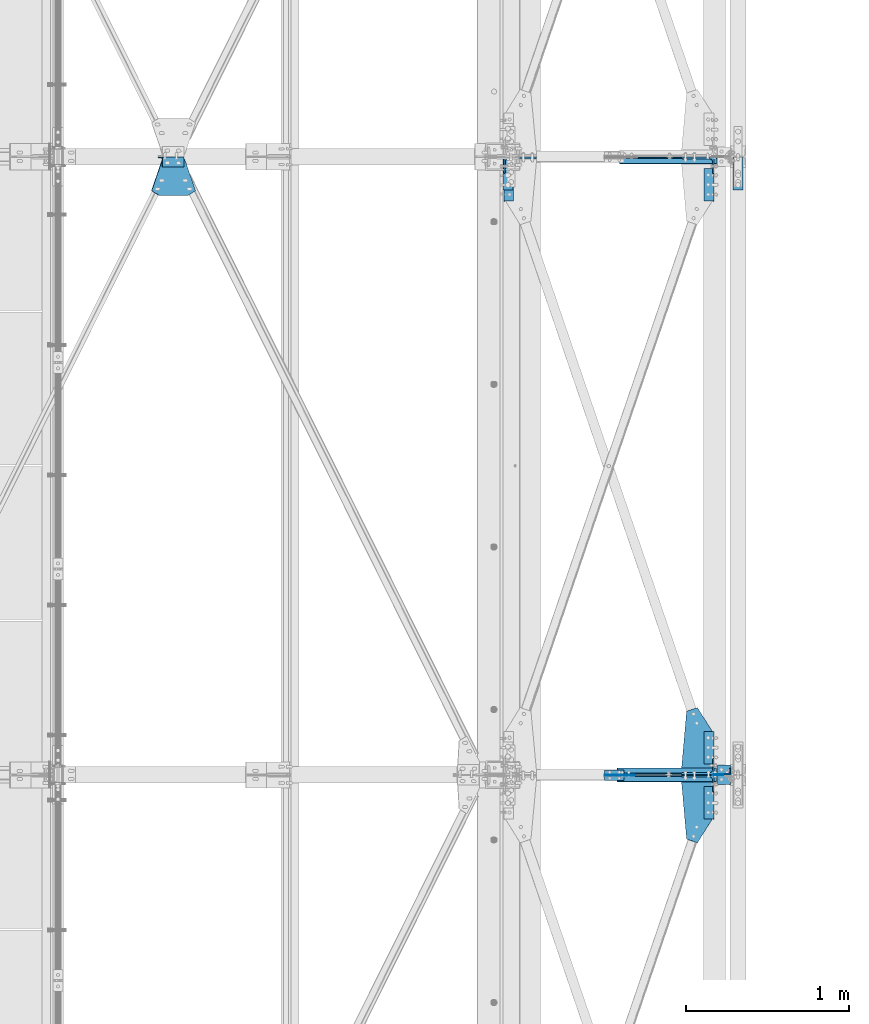
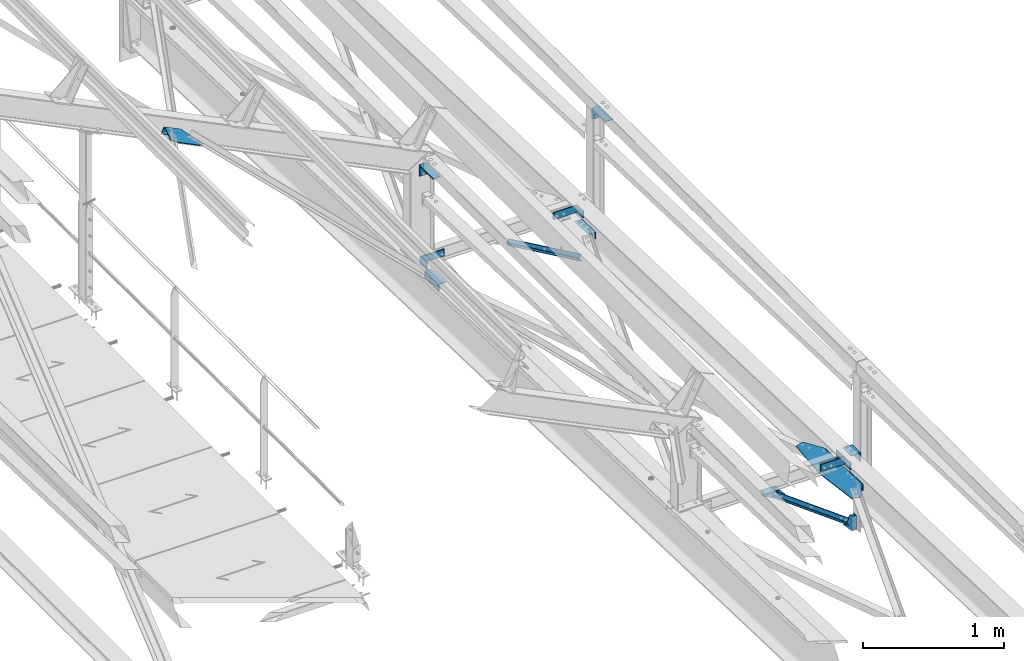
# One storey, part 109 of 496: 13 beams, 8 members, 20 elements without a shape of their own.
"""IFC2X3 building model written with IfcOpenShell, lengths in millimetres."""

from ifc_helpers import new_model, si_unit, frame, origin_with_axes, origin_2d_with_axis, place, context, subcontext, project, spatial, polyline, rectangle, l_section, outline, extrude, clip, halfspace, material, type_object, element, aggregate, save


model = new_model("IFC2X3")

# Units and contexts
model_context = context("Model", 3, precision=1e-05, world=origin_with_axes())
body_context = subcontext(model_context, "Body", "Model", "MODEL_VIEW")
ifc_project = project(units=[si_unit("LENGTHUNIT", "METRE", prefix="MILLI"), si_unit("AREAUNIT", "SQUARE_METRE"), si_unit("VOLUMEUNIT", "CUBIC_METRE"), si_unit("MASSUNIT", "GRAM", prefix="KILO"), si_unit("TIMEUNIT", "SECOND"), si_unit("PLANEANGLEUNIT", "RADIAN"), si_unit("SOLIDANGLEUNIT", "STERADIAN"), si_unit("THERMODYNAMICTEMPERATUREUNIT", "DEGREE_CELSIUS"), si_unit("LUMINOUSINTENSITYUNIT", "LUMEN")], contexts=[model_context])

# Site, building, storey
site_placement = place(None, origin_with_axes())
site = spatial("IfcSite", under=ifc_project, at=site_placement, CompositionType="ELEMENT")
building_placement = place(site_placement, origin_with_axes())
building = spatial("IfcBuilding", under=site, at=building_placement, Name="Undefined", CompositionType="ELEMENT")
storey_placement = place(building_placement, origin_with_axes())
storey = spatial("IfcBuildingStorey", under=building, at=storey_placement, Name="Undefined", CompositionType="ELEMENT", Elevation=0.0)

# Assembly, beam
assembly_1_placement = place(storey_placement, origin_with_axes())
assembly_1 = element("IfcElementAssembly", 1, at=assembly_1_placement, inside=storey, AssemblyPlace="NOTDEFINED", PredefinedType="NOTDEFINED")
ifc_material = material(Name="Undefined/S235-E24")
beam_type_1 = type_object("IfcBeamType", PredefinedType="NOTDEFINED")
beam_1_placement = place(assembly_1_placement, frame((39596.4999999987, 7327.11779121703, 7663.65903284788), z_axis=(0.0, -0.031410887010906, -0.999506556345274), x_axis=(0.0, 0.999506556345274, -0.0314108870109058)))
beam_1 = element("IfcBeam", 2, at=beam_1_placement, type_object=beam_type_1, material=ifc_material, context=body_context, shape_type="SweptSolid", body=[
    extrude(l_section(Depth=60.0, Width=60.0, Thickness=6.0, FilletRadius=8.0, EdgeRadius=4.0, at=origin_2d_with_axis()), frame((200.0, 0.0, 0.0), z_axis=(-1.0, 0.0, 0.0), x_axis=(0.0, -1.0, 0.0)), (0.0, 0.0, 1.0), 200.0),
])
aggregate(assembly_1, [beam_1])

assembly_2_placement = place(storey_placement, origin_with_axes())
assembly_2 = element("IfcElementAssembly", 3, at=assembly_2_placement, inside=storey, AssemblyPlace="NOTDEFINED", PredefinedType="NOTDEFINED")
beam_2_placement = place(assembly_2_placement, frame((39596.4999999987, 7666.95002289422, 7652.97941150256), z_axis=(0.0, -0.031410887010906, -0.999506556345274), x_axis=(0.0, 0.999506556345274, -0.0314108870109058)))
beam_2 = element("IfcBeam", 4, at=beam_2_placement, type_object=beam_type_1, material=ifc_material, context=body_context, shape_type="SweptSolid", body=[
    extrude(l_section(Depth=60.0, Width=60.0, Thickness=6.0, FilletRadius=8.0, EdgeRadius=4.0, at=origin_2d_with_axis()), frame((200.0, 0.0, 0.0), z_axis=(-1.0, 0.0, 0.0), x_axis=(0.0, -1.0, 0.0)), (0.0, 0.0, 1.0), 200.0),
])
aggregate(assembly_2, [beam_2])

assembly_3_placement = place(storey_placement, origin_with_axes())
assembly_3 = element("IfcElementAssembly", 5, at=assembly_3_placement, inside=storey, AssemblyPlace="NOTDEFINED", PredefinedType="NOTDEFINED")
beam_3_placement = place(assembly_3_placement, frame((39596.4999999987, 11127.1177919487, 7544.23922211323), z_axis=(0.0, -0.031410887010906, -0.999506556345274), x_axis=(0.0, 0.999506556345274, -0.0314108870109058)))
beam_3 = element("IfcBeam", 6, at=beam_3_placement, type_object=beam_type_1, material=ifc_material, context=body_context, shape_type="SweptSolid", body=[
    extrude(l_section(Depth=60.0, Width=60.0, Thickness=6.0, FilletRadius=8.0, EdgeRadius=4.0, at=origin_2d_with_axis()), frame((200.0, 0.0, 0.0), z_axis=(-1.0, 0.0, 0.0), x_axis=(0.0, -1.0, 0.0)), (0.0, 0.0, 1.0), 200.0),
])
aggregate(assembly_3, [beam_3])

assembly_4_placement = place(storey_placement, origin_with_axes())
assembly_4 = element("IfcElementAssembly", 7, at=assembly_4_placement, inside=storey, AssemblyPlace="NOTDEFINED", PredefinedType="NOTDEFINED")
beam_4_placement = place(assembly_4_placement, frame((38365.0000000024, 11327.0191028577, 7537.95703356359), z_axis=(0.0, -0.031410887010906, -0.999506556345274), x_axis=(0.0, -0.999506556345276, 0.031410887010852)))
beam_4 = element("IfcBeam", 8, at=beam_4_placement, type_object=beam_type_1, material=ifc_material, context=body_context, shape_type="SweptSolid", body=[
    extrude(l_section(Depth=60.0, Width=60.0, Thickness=6.0, FilletRadius=8.0, EdgeRadius=4.0, at=origin_2d_with_axis()), frame((200.0, 0.0, 0.0), z_axis=(-1.0, 0.0, 0.0), x_axis=(0.0, -1.0, 0.0)), (0.0, 0.0, 1.0), 200.0),
])
aggregate(assembly_4, [beam_4])

assembly_5_placement = place(storey_placement, origin_with_axes())
assembly_5 = element("IfcElementAssembly", 9, at=assembly_5_placement, inside=storey, AssemblyPlace="NOTDEFINED", PredefinedType="NOTDEFINED")
beam_type_2 = type_object("IfcBeamType", PredefinedType="NOTDEFINED")
beam_5_placement = place(assembly_5_placement, frame((39689.0, 7660.12744744233, 7759.04601471418), z_axis=(-1.0, 0.0, 0.0), x_axis=(0.0, -0.999506556345276, 0.031410887010852)))
beam_5 = element("IfcBeam", 10, at=beam_5_placement, type_object=beam_type_2, material=ifc_material, context=body_context, shape_type="SweptSolid", body=[
    extrude(l_section(Depth=80.0, Width=80.0, Thickness=8.0, FilletRadius=10.0, EdgeRadius=5.0, at=origin_2d_with_axis()), frame((120.0, 0.0, 0.0), z_axis=(-1.0, 0.0, 0.0), x_axis=(0.0, -1.0, 0.0)), (0.0, 0.0, 1.0), 120.0),
])
aggregate(assembly_5, [beam_5])

assembly_6_placement = place(storey_placement, origin_with_axes())
assembly_6 = element("IfcElementAssembly", 11, at=assembly_6_placement, inside=storey, AssemblyPlace="NOTDEFINED", PredefinedType="NOTDEFINED")
beam_type_3 = type_object("IfcBeamType", PredefinedType="NOTDEFINED")
beam_6_placement = place(assembly_6_placement, frame((39709.0000003665, 7623.0, 7220.00000925125), z_axis=(-1.0, 0.0, 0.0), x_axis=(0.0, 0.0, -1.0)))
beam_6 = element("IfcBeam", 12, at=beam_6_placement, type_object=beam_type_3, material=ifc_material, context=body_context, shape_type="SweptSolid", body=[
    extrude(l_section(Depth=40.0, Width=40.0, Thickness=4.0, FilletRadius=6.0, EdgeRadius=3.0, at=origin_2d_with_axis()), frame((120.0, 0.0, 0.0), z_axis=(-1.0, 0.0, 0.0), x_axis=(0.0, -1.0, 0.0)), (0.0, 0.0, 1.0), 120.0),
])
aggregate(assembly_6, [beam_6])

# Assembly, member
assembly_7_placement = place(storey_placement, origin_with_axes())
assembly_7 = element("IfcElementAssembly", 13, at=assembly_7_placement, inside=storey, AssemblyPlace="NOTDEFINED", PredefinedType="NOTDEFINED")
member_type_1 = type_object("IfcMemberType", PredefinedType="NOTDEFINED")
member_1_placement = place(assembly_7_placement, frame((36221.8078542171, 11367.0004540967, 9484.14527223568), z_axis=(0.0, -1.0, 0.0), x_axis=(0.897398510539058, 0.0, -0.441220934773362)))
member_1 = element("IfcMember", 14, at=member_1_placement, type_object=member_type_1, material=ifc_material, context=body_context, shape_type="SweptSolid", body=[
    extrude(l_section(Depth=60.0, Width=60.0, Thickness=6.0, FilletRadius=8.0, EdgeRadius=4.0, at=origin_2d_with_axis()), frame((149.999995982835, 4.54747350886464e-12, 3.63797880709171e-12), z_axis=(-1.0, 0.0, 0.0), x_axis=(0.0, -1.0, 0.0)), (0.0, 0.0, 1.0), 150.0),
])
aggregate(assembly_7, [member_1])

assembly_8_placement = place(storey_placement, origin_with_axes())
assembly_8 = element("IfcElementAssembly", 15, at=assembly_8_placement, inside=storey, AssemblyPlace="NOTDEFINED", PredefinedType="NOTDEFINED")
member_type_2 = type_object("IfcMemberType", PredefinedType="NOTDEFINED")
member_2_placement = place(assembly_8_placement, frame((39526.4999999999, 11345.7696869632, 7593.39548474004), z_axis=(-1.0, 0.0, 0.0), x_axis=(0.0, 0.031410887010906, 0.999506556345274)))
member_2 = element("IfcMember", 16, at=member_2_placement, type_object=member_type_2, material=ifc_material, context=body_context, shape_type="SweptSolid", body=[
    extrude(l_section(Depth=200.0, Width=100.0, Thickness=10.0, FilletRadius=15.0, EdgeRadius=7.5, at=origin_2d_with_axis()), frame((60.0, 0.0, 0.0), z_axis=(-1.0, 0.0, 0.0), x_axis=(0.0, -1.0, 0.0)), (0.0, 0.0, 1.0), 60.0),
])
aggregate(assembly_8, [member_2])

assembly_9_placement = place(storey_placement, origin_with_axes())
assembly_9 = element("IfcElementAssembly", 17, at=assembly_9_placement, inside=storey, AssemblyPlace="NOTDEFINED", PredefinedType="NOTDEFINED")
member_3_placement = place(assembly_9_placement, frame((39526.5, 7653.60293699989, 7769.45603246102), z_axis=(-1.0, 0.0, 0.0), x_axis=(0.0, -0.031410887010906, -0.999506556345274)))
member_3 = element("IfcMember", 18, at=member_3_placement, type_object=member_type_2, material=ifc_material, context=body_context, shape_type="SweptSolid", body=[
    extrude(l_section(Depth=200.0, Width=100.0, Thickness=10.0, FilletRadius=15.0, EdgeRadius=7.5, at=origin_2d_with_axis()), frame((60.0, 0.0, 0.0), z_axis=(-1.0, 0.0, 0.0), x_axis=(0.0, -1.0, 0.0)), (0.0, 0.0, 1.0), 60.0),
])
aggregate(assembly_9, [member_3])

assembly_10_placement = place(storey_placement, origin_with_axes())
assembly_10 = element("IfcElementAssembly", 19, at=assembly_10_placement, inside=storey, AssemblyPlace="NOTDEFINED", PredefinedType="NOTDEFINED")
member_4_placement = place(assembly_10_placement, frame((39526.4999999999, 7545.76968615642, 7712.81529547544), z_axis=(-1.0, 0.0, 0.0), x_axis=(0.0, 0.031410887010906, 0.999506556345274)))
member_4 = element("IfcMember", 20, at=member_4_placement, type_object=member_type_2, material=ifc_material, context=body_context, shape_type="SweptSolid", body=[
    extrude(l_section(Depth=200.0, Width=100.0, Thickness=10.0, FilletRadius=15.0, EdgeRadius=7.5, at=origin_2d_with_axis()), frame((60.0, 0.0, 0.0), z_axis=(-1.0, 0.0, 0.0), x_axis=(0.0, -1.0, 0.0)), (0.0, 0.0, 1.0), 60.0),
])
aggregate(assembly_10, [member_4])

assembly_11_placement = place(storey_placement, origin_with_axes())
assembly_11 = element("IfcElementAssembly", 21, at=assembly_11_placement, inside=storey, AssemblyPlace="NOTDEFINED", PredefinedType="NOTDEFINED")
member_5_placement = place(assembly_11_placement, frame((38435.0000000001, 11347.6543832966, 7653.36587676423), z_axis=(1.0, 0.0, 0.0), x_axis=(0.0, -0.031410887010906, -0.999506556345274)))
member_5 = element("IfcMember", 22, at=member_5_placement, type_object=member_type_2, material=ifc_material, context=body_context, shape_type="SweptSolid", body=[
    extrude(l_section(Depth=200.0, Width=100.0, Thickness=10.0, FilletRadius=15.0, EdgeRadius=7.5, at=origin_2d_with_axis()), frame((60.0, 0.0, 0.0), z_axis=(-1.0, 0.0, 0.0), x_axis=(0.0, -1.0, 0.0)), (0.0, 0.0, 1.0), 60.0),
])
aggregate(assembly_11, [member_5])

# Assembly, beam
assembly_12_placement = place(storey_placement, origin_with_axes())
assembly_12 = element("IfcElementAssembly", 23, at=assembly_12_placement, inside=storey, AssemblyPlace="NOTDEFINED", PredefinedType="NOTDEFINED")
beam_type_4 = type_object("IfcBeamType", PredefinedType="NOTDEFINED")
beam_7_placement = place(assembly_12_placement, frame((39745.0, 11296.5, 8400.0), z_axis=(0.0, -1.0, 0.0), x_axis=(1.0, 0.0, 0.0)))
beam_7 = element("IfcBeam", 24, at=beam_7_placement, type_object=beam_type_4, material=ifc_material, context=body_context, shape_type="SweptSolid", body=[
    extrude(l_section(Depth=200.0, Width=100.0, Thickness=10.0, FilletRadius=15.0, EdgeRadius=7.5, at=origin_2d_with_axis()), frame((60.0, 0.0, 0.0), z_axis=(-1.0, 0.0, 0.0), x_axis=(0.0, -1.0, 0.0)), (0.0, 0.0, 1.0), 60.0),
])
aggregate(assembly_12, [beam_7])

assembly_13_placement = place(storey_placement, origin_with_axes())
assembly_13 = element("IfcElementAssembly", 25, at=assembly_13_placement, inside=storey, AssemblyPlace="NOTDEFINED", PredefinedType="NOTDEFINED")
beam_8_placement = place(assembly_13_placement, frame((38330.0, 11296.5, 8400.0), z_axis=(0.0, -1.0, 0.0), x_axis=(1.0, 0.0, 0.0)))
beam_8 = element("IfcBeam", 26, at=beam_8_placement, type_object=beam_type_4, material=ifc_material, context=body_context, shape_type="SweptSolid", body=[
    extrude(l_section(Depth=200.0, Width=100.0, Thickness=10.0, FilletRadius=15.0, EdgeRadius=7.5, at=origin_2d_with_axis()), frame((60.0, 0.0, 0.0), z_axis=(-1.0, 0.0, 0.0), x_axis=(0.0, -1.0, 0.0)), (0.0, 0.0, 1.0), 60.0),
])
aggregate(assembly_13, [beam_8])

assembly_14_placement = place(storey_placement, origin_with_axes())
assembly_14 = element("IfcElementAssembly", 27, at=assembly_14_placement, inside=storey, AssemblyPlace="NOTDEFINED", PredefinedType="NOTDEFINED")
beam_type_5 = type_object("IfcBeamType", PredefinedType="NOTDEFINED")
beam_9_placement = place(assembly_14_placement, frame((36370.977930529, 11387.0005570451, 9447.57627824905), z_axis=(0.441221071222121, 0.0, 0.897398443451739), x_axis=(-0.897398510539055, -1.29999898490537e-08, 0.441220934773368)))
beam_9 = element("IfcBeam", 28, at=beam_9_placement, type_object=beam_type_5, material=ifc_material, context=body_context, shape_type="SweptSolid", body=[
    extrude(outline(polyline([(0.0, 0.0), (149.999999999138, -4.0381564758718e-10), (225.299438472997, 196.258819581493), (172.823120113848, 225.348953248153), (-22.830436708522, 225.348953246928), (-75.3067550673877, 196.258804320814), (0.0, 0.0)])), frame((0.0, 0.0, -3.0), z_axis=(0.0, 0.0, 1.0), x_axis=(1.0, 0.0, 0.0)), (0.0, 0.0, 1.0), 6.0),
])
aggregate(assembly_14, [beam_9])

# Assembly, beams
assembly_15_placement = place(storey_placement, origin_with_axes())
assembly_15 = element("IfcElementAssembly", 29, at=assembly_15_placement, inside=storey, AssemblyPlace="NOTDEFINED", PredefinedType="NOTDEFINED")
beam_type_6 = type_object("IfcBeamType", PredefinedType="NOTDEFINED")
beam_10_placement = place(assembly_15_placement, frame((39015.0, 7630.00533210934, 7687.15667204717), z_axis=(1.0, 0.0, 0.0), x_axis=(0.0, -0.999506556345276, 0.031410887010852)))
beam_10 = element("IfcBeam", 30, at=beam_10_placement, type_object=beam_type_6, material=ifc_material, context=body_context, shape_type="SweptSolid", body=[
    extrude(rectangle(XDim=6.0, YDim=120.0, at=origin_2d_with_axis()), frame((63.999999999927, 0.0, 0.0), z_axis=(-1.0, 0.0, 0.0), x_axis=(0.0, -1.0, 0.0)), (0.0, 0.0, 1.0), 64.0),
])
beam_type_7 = type_object("IfcBeamType", PredefinedType="NOTDEFINED")
beam_11_placement = place(assembly_15_placement, frame((38955.0, 7598.12, 7685.00386774712), z_axis=(0.0, -1.0, 0.0), x_axis=(0.0, 0.0, -1.0)))
beam_11 = element("IfcBeam", 31, at=beam_11_placement, type_object=beam_type_7, material=ifc_material, context=body_context, shape_type="SweptSolid", body=[
    extrude(outline(polyline([(0.0, 0.0), (24.9957141876221, 0.0), (108.967063903809, 153.952651977539), (68.7210540771484, 183.621810913086), (-2.37123549595708e-06, 120.0), (0.0, 0.0)])), frame((0.0, 0.0, -3.0), z_axis=(0.0, 0.0, 1.0), x_axis=(1.0, 0.0, 0.0)), (0.0, 0.0, 1.0), 6.0),
])
aggregate(assembly_15, [beam_11, beam_10])

# Assembly, beam
assembly_16_placement = place(storey_placement, origin_with_axes())
assembly_16 = element("IfcElementAssembly", 32, at=assembly_16_placement, inside=storey, AssemblyPlace="NOTDEFINED", PredefinedType="NOTDEFINED")
beam_type_8 = type_object("IfcBeamType", PredefinedType="NOTDEFINED")
beam_12_placement = place(assembly_16_placement, frame((39557.6581373788, 7600.0, 7245.2533864876), z_axis=(0.0, -1.0, 0.0), x_axis=(0.67069467174469, 0.0, -0.741733548717653)))
beam_12 = element("IfcBeam", 33, at=beam_12_placement, type_object=beam_type_8, material=ifc_material, context=body_context, shape_type="Clipping", body=[
    clip(extrude(outline(polyline([(0.0, 0.0), (195.829589844598, 3.78349795937538e-10), (222.657379151449, 29.6693420422525), (133.649353028268, 110.152702333078), (-9.95287132252633, 48.9993896488158), (0.0, 0.0)])), frame((0.0, 0.0, -3.0), z_axis=(0.0, 0.0, 1.0), x_axis=(1.0, 0.0, 0.0)), (0.0, 0.0, 1.0), 6.0), halfspace(frame((82.4508639261912, 70.6515813380975, 9.09494701772928e-13), z_axis=(-0.994710896578578, -0.1027143233821, 0.0), x_axis=(0.0, 0.0, 1.0)), False)),
])
aggregate(assembly_16, [beam_12])

assembly_17_placement = place(storey_placement, origin_with_axes())
assembly_17 = element("IfcElementAssembly", 34, at=assembly_17_placement, inside=storey, AssemblyPlace="NOTDEFINED", PredefinedType="NOTDEFINED")
beam_type_9 = type_object("IfcBeamType", PredefinedType="NOTDEFINED")
beam_13_placement = place(assembly_17_placement, frame((39458.4935659348, 7991.22326197496, 7675.80496792342), z_axis=(0.0, 0.031410887010906, 0.999506556345274), x_axis=(-0.0881827810005833, -0.995612793006633, 0.0312883930002095)))
beam_13 = element("IfcBeam", 35, at=beam_13_placement, type_object=beam_type_9, material=ifc_material, context=body_context, shape_type="SweptSolid", body=[
    extrude(outline(polyline([(0.0, 0.0), (362.809631347498, 9.74978320300579e-10), (426.560333251671, 5.64369726283621), (783.729370116189, 69.3817214974551), (800.448486327015, 137.355758667814), (646.878417967828, 215.891021729345), (108.982093811137, 168.272323609417), (-28.4006748194752, 63.9796981823019), (0.0, 0.0)])), frame((0.0, 0.0, -3.0), z_axis=(0.0, 0.0, 1.0), x_axis=(1.0, 0.0, 0.0)), (0.0, 0.0, 1.0), 6.0),
])
aggregate(assembly_17, [beam_13])

# Assembly, member
assembly_18_placement = place(storey_placement, origin_with_axes())
assembly_18 = element("IfcElementAssembly", 36, at=assembly_18_placement, inside=storey, AssemblyPlace="NOTDEFINED", PredefinedType="NOTDEFINED")
member_type_3 = type_object("IfcMemberType", PredefinedType="NOTDEFINED")
member_6_placement = place(assembly_18_placement, frame((38994.0037125582, 11377.000384057, 7569.94708237643), z_axis=(0.49814372323054, 0.0, 0.867094476401514), x_axis=(0.867094475969523, 0.0, -0.498143723982485)))
member_6 = element("IfcMember", 37, at=member_6_placement, type_object=member_type_3, material=ifc_material, context=body_context, shape_type="Clipping", body=[
    clip(clip(extrude(l_section(Depth=40.0, Width=40.0, Thickness=4.0, FilletRadius=6.0, EdgeRadius=3.0, at=origin_2d_with_axis()), frame((793.784756375447, 0.0, 0.0), z_axis=(-1.0, 0.0, 0.0), x_axis=(0.0, -1.0, 0.0)), (0.0, 0.0, 1.0), 758.69), halfspace(frame((758.884192569196, 22.9996159161474, 20.0), z_axis=(1.0, 0.0, 0.0), x_axis=(0.0, 1.0, 0.0)), False)), halfspace(frame((70.0000000000655, 22.9996159161474, 20.0), z_axis=(1.0, 0.0, 0.0), x_axis=(0.0, 1.0, 0.0)), True)),
])
aggregate(assembly_18, [member_6])

assembly_19_placement = place(storey_placement, origin_with_axes())
assembly_19 = element("IfcElementAssembly", 38, at=assembly_19_placement, inside=storey, AssemblyPlace="NOTDEFINED", PredefinedType="NOTDEFINED")
member_7_placement = place(assembly_19_placement, frame((38993.8132338066, 7577.00038405624, 7689.49126830137), z_axis=(0.593383099011782, 0.0, 0.804920181016213), x_axis=(0.804920185642413, 0.0, -0.593383092736373)))
member_7 = element("IfcMember", 39, at=member_7_placement, type_object=member_type_3, material=ifc_material, context=body_context, shape_type="Clipping", body=[
    clip(clip(extrude(l_section(Depth=40.0, Width=40.0, Thickness=4.0, FilletRadius=6.0, EdgeRadius=3.0, at=origin_2d_with_axis()), frame((856.045576199555, 0.0, 0.0), z_axis=(-1.0, 0.0, 0.0), x_axis=(0.0, -1.0, 0.0)), (0.0, 0.0, 1.0), 834.64), halfspace(frame((817.453392857526, 22.9996159437633, 19.9999999999927), z_axis=(-1.0, 0.0, 0.0), x_axis=(0.0, -1.0, 0.0)), True)), halfspace(frame((60.0000000000509, 22.9996159437633, 20.0), z_axis=(-1.0, 0.0, 0.0), x_axis=(0.0, -1.0, 0.0)), False)),
])
aggregate(assembly_19, [member_7])

assembly_20_placement = place(storey_placement, origin_with_axes())
assembly_20 = element("IfcElementAssembly", 40, at=assembly_20_placement, inside=storey, AssemblyPlace="NOTDEFINED", PredefinedType="NOTDEFINED")
member_8_placement = place(assembly_20_placement, frame((39727.813233827, 7623.00038408325, 7148.39016895038), z_axis=(0.593383099011782, 0.0, 0.804920181016213), x_axis=(-0.804920181016213, 0.0, 0.593383099011783)))
member_8 = element("IfcMember", 41, at=member_8_placement, type_object=member_type_3, material=ifc_material, context=body_context, shape_type="Clipping", body=[
    clip(clip(extrude(l_section(Depth=40.0, Width=40.0, Thickness=4.0, FilletRadius=6.0, EdgeRadius=3.0, at=origin_2d_with_axis()), frame((890.483843435856, 0.0, 0.0), z_axis=(-1.0, 0.0, 0.0), x_axis=(0.0, -1.0, 0.0)), (0.0, 0.0, 1.0), 834.64), halfspace(frame((851.891660093821, 23.000384083246, 20.0000001508124), z_axis=(1.0, 0.0, 0.0), x_axis=(0.0, 1.0, 0.0)), False)), halfspace(frame((94.4382672363463, 23.000384083246, 20.0000001508051), z_axis=(1.0, 0.0, 0.0), x_axis=(0.0, 1.0, 0.0)), True)),
])
aggregate(assembly_20, [member_8])

save(model, "model.ifc")
